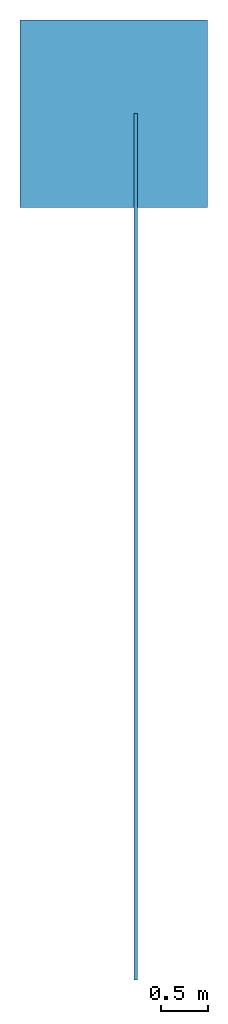
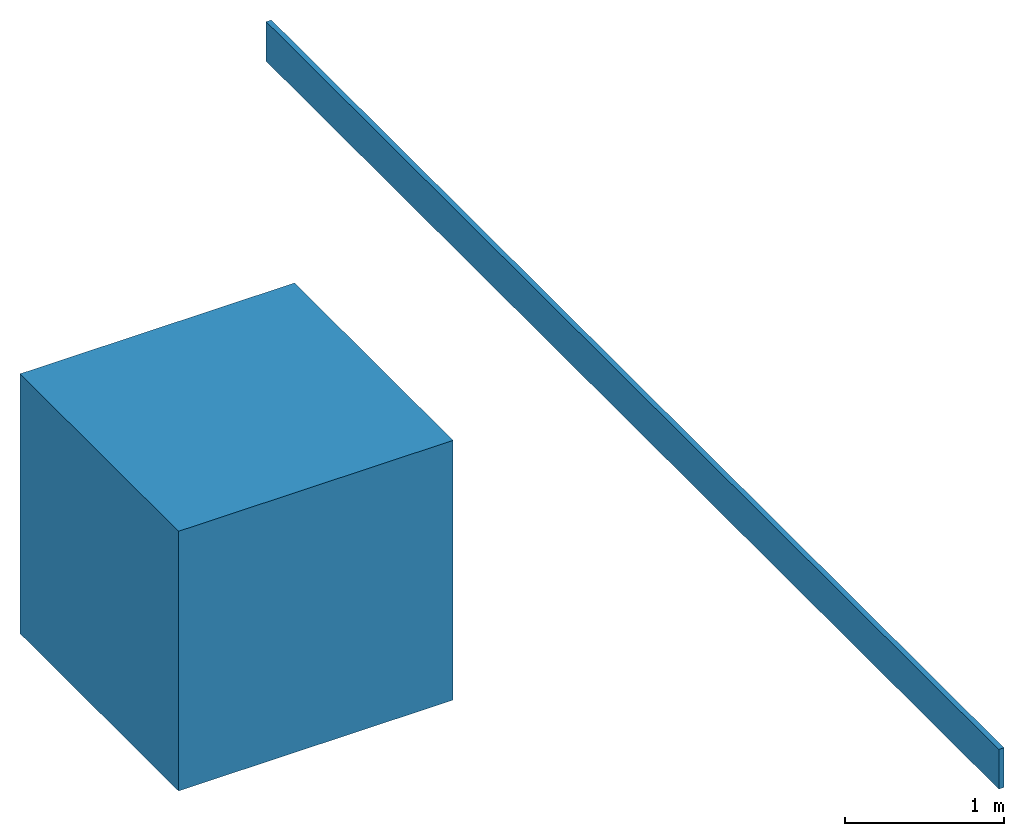
# Not in any storey: 1 beam, 1 member.
"""IFC4 building model written with IfcOpenShell, lengths in inches."""

from ifc_helpers import new_model, entity, si_unit, converted_unit, frame, origin_with_axes, origin_2d_with_axis, place, context, subcontext, project, spatial, indexed_curve, outline, extrude, polygons, material, layer, layer_set, layer_usage, type_object, element, save


model = new_model("IFC4")

# Units and contexts
model_context = context("Model", 3, precision=1e-05, world=origin_with_axes())
plan_context = context("Plan", 2, precision=1e-05, world=origin_2d_with_axis())
body_context = subcontext(model_context, "Body", "Model", "MODEL_VIEW")
ifc_project = project(units=[converted_unit("PLANEANGLEUNIT", "degree", entity("IfcReal", 0.0174532925199433), si_unit("PLANEANGLEUNIT", "RADIAN"), dimensions=[0, 0, 0, 0, 0, 0, 0]), converted_unit("AREAUNIT", "square inch", entity("IfcReal", 0.0006452), si_unit("AREAUNIT", "SQUARE_METRE"), dimensions=[2, 0, 0, 0, 0, 0, 0]), converted_unit("LENGTHUNIT", "inch", entity("IfcReal", 0.0254), si_unit("LENGTHUNIT", "METRE"), dimensions=[1, 0, 0, 0, 0, 0, 0]), converted_unit("VOLUMEUNIT", "cubic inch", entity("IfcReal", 1.639e-05), si_unit("VOLUMEUNIT", "CUBIC_METRE"), dimensions=[3, 0, 0, 0, 0, 0, 0])], contexts=[model_context, plan_context])

# Member
ifc_material = material(Name="Default")
ifc_layer = layer(ifc_material, 1.5, Name="2x12 wood chord")
ifc_layer_set = layer_set([ifc_layer], Name="2x12 wood chord")
ifc_layer_usage = layer_usage(ifc_layer_set, "AXIS2", "POSITIVE", 0.0)
member_type = type_object("IfcMemberType", Name="2x12 wood chord", PredefinedType="CHORD", material=ifc_layer_set)
member_placement = place(None, frame((632.999900757797, -357.879090496874, 109.012492998378), z_axis=(0.0, 0.0, 1.0), x_axis=(3.13916473260178e-07, 1.0, 0.0)))
element("IfcMember", 1, at=member_placement, type_object=member_type, material=ifc_layer_usage, Name="Member", PredefinedType="NOTDEFINED", context=body_context, shape_type="SweptSolid", body=[
    extrude(outline(indexed_curve([(0.0, 0.0), (0.0, 1.5), (363.879055554429, 1.5), (363.879055554429, 0.0), (0.0, 0.0)], self_intersect=False)), origin_with_axes(), (0.0, 0.0, 1.0), 12.0),
])

# Site, building
site_placement = place(None, origin_with_axes())
site = spatial("IfcSite", under=ifc_project, at=site_placement)
building_placement = place(site_placement, frame((0.0, 0.0, 109.012492998378), z_axis=(0.0, 0.0, 1.0), x_axis=(1.0, 0.0, 0.0)))
building = spatial("IfcBuilding", under=site, at=building_placement, Name="Building")

# Beam
beam_placement = place(building_placement, frame((623.000212541715, 6.00001943393016, -141.231244004618), z_axis=(0.0, 0.0, 1.0), x_axis=(1.0, 0.0, 0.0)))
element("IfcBeam", 2, at=beam_placement, inside=building, Name="Beam", PredefinedType="NOTDEFINED", context=body_context, shape_type="Tessellation", body=[
    polygons([(-39.3700790405273, -39.3700790405273, -39.3700790405273), (-39.3700790405273, -39.3700790405273, 39.3700790405273), (-39.3700790405273, 39.3700790405273, -39.3700790405273), (-39.3700790405273, 39.3700790405273, 39.3700790405273), (39.3700790405273, -39.3700790405273, -39.3700790405273), (39.3700790405273, -39.3700790405273, 39.3700790405273), (39.3700790405273, 39.3700790405273, -39.3700790405273), (39.3700790405273, 39.3700790405273, 39.3700790405273)], [[[1, 2, 4, 3]], [[3, 4, 8, 7]], [[7, 8, 6, 5]], [[5, 6, 2, 1]], [[3, 7, 5, 1]], [[8, 4, 2, 6]]]),
])

save(model, "model.ifc")
